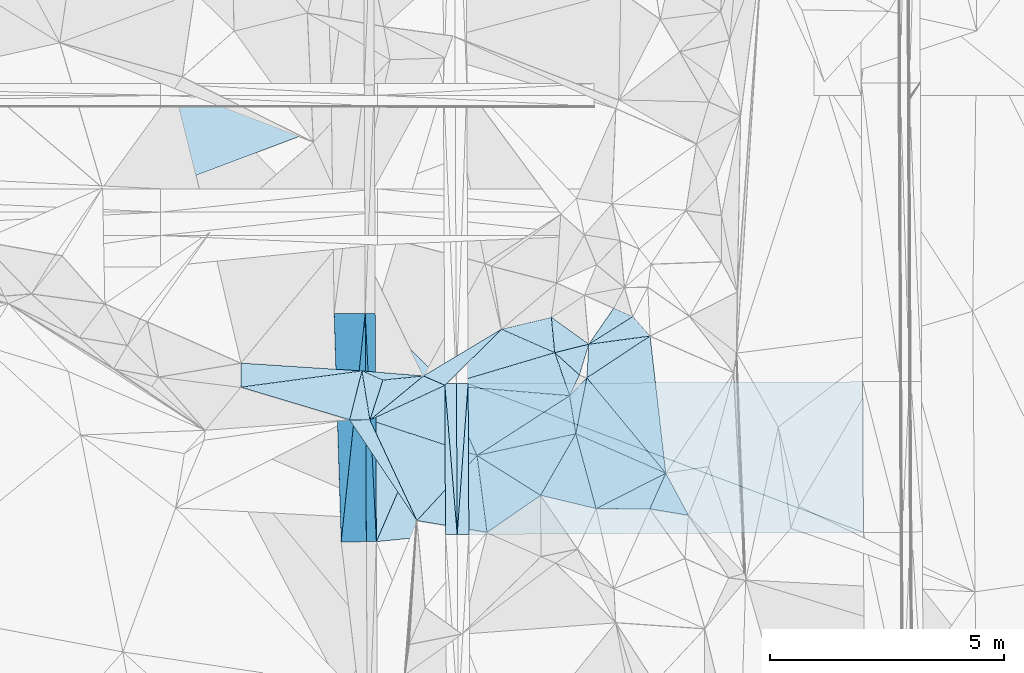
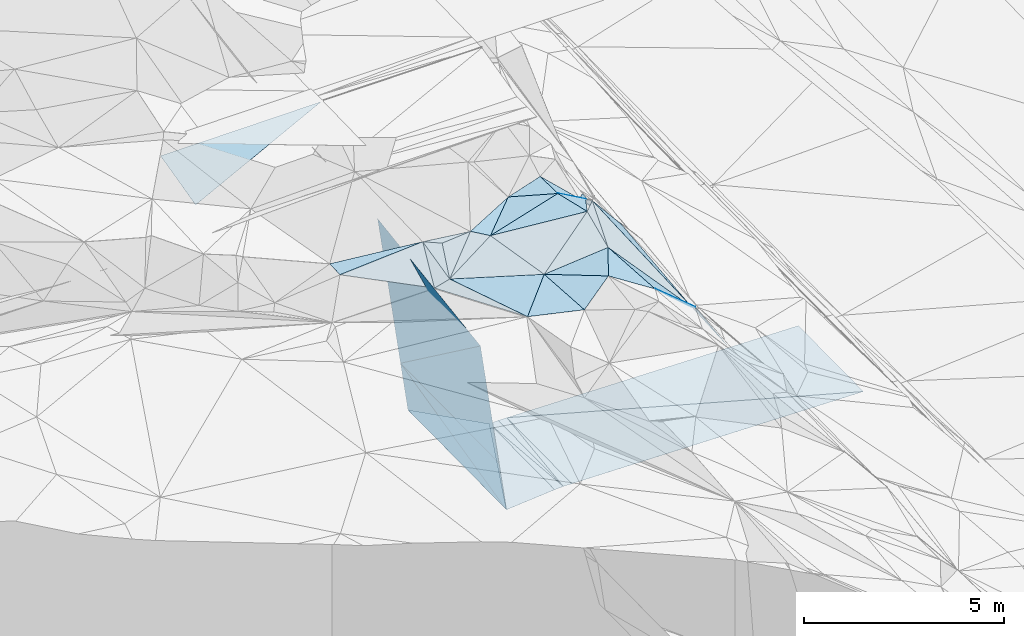
# One storey, part 58 of 275: 45 plates.
"""IFC2X3 building model written with IfcOpenShell, lengths in millimetres."""

from ifc_helpers import new_model, si_unit, frame, origin_with_axes, place, context, subcontext, project, spatial, polyline, outline, extrude, material, type_object, element, save


model = new_model("IFC2X3")

# Units and contexts
model_context = context("Model", 3, precision=1e-05, world=origin_with_axes())
body_context = subcontext(model_context, "Body", "Model", "MODEL_VIEW")
ifc_project = project(units=[si_unit("LENGTHUNIT", "METRE", prefix="MILLI"), si_unit("AREAUNIT", "SQUARE_METRE"), si_unit("VOLUMEUNIT", "CUBIC_METRE"), si_unit("MASSUNIT", "GRAM", prefix="KILO"), si_unit("TIMEUNIT", "SECOND"), si_unit("PLANEANGLEUNIT", "RADIAN"), si_unit("SOLIDANGLEUNIT", "STERADIAN"), si_unit("THERMODYNAMICTEMPERATUREUNIT", "DEGREE_CELSIUS"), si_unit("LUMINOUSINTENSITYUNIT", "LUMEN")], contexts=[model_context])

# Site, building, storey
site_placement = place(None, origin_with_axes())
site = spatial("IfcSite", under=ifc_project, at=site_placement, CompositionType="ELEMENT")
building_placement = place(site_placement, origin_with_axes())
building = spatial("IfcBuilding", under=site, at=building_placement, Name="Undefined", CompositionType="ELEMENT")
storey_placement = place(building_placement, origin_with_axes())
storey = spatial("IfcBuildingStorey", under=building, at=storey_placement, Name="Undefined", CompositionType="ELEMENT", Elevation=0.0)

# Plates
ifc_material = material()
plate_type_1 = type_object("IfcPlateType", PredefinedType="NOTDEFINED")
plate_1_placement = place(storey_placement, frame((-103762.046653991, 50894.1694006968, 42279.068715514), z_axis=(0.0498269203156431, 0.0192892523442548, -0.998571581187778), x_axis=(-0.998738273714804, -0.00530039909850709, -0.0499376249592364)))
element("IfcPlate", 1, at=plate_1_placement, inside=storey, type_object=plate_type_1, material=ifc_material, Name="00_PR", context=body_context, shape_type="SweptSolid", body=[
    extrude(outline(polyline([(0.0, 0.0), (250.312271118164, 1.46246748045087e-09), (246.36457824707, 3230.80200195313), (0.0, 0.0)])), frame((-8.85201319254618e-08, 2.18876761149539e-07, -0.5000001331573), z_axis=(0.0, 0.0, 1.0), x_axis=(1.0, 0.0, 0.0)), (0.0, 0.0, 1.0), 1.0),
])
plate_2_placement = place(storey_placement, frame((-104028.312565515, 54123.0191331993, 42328.1537156692), z_axis=(0.0498371754160968, 0.0192900898061219, -0.998571053246496), x_axis=(0.998740995725731, 0.00476009109940219, 0.0499376109710982)))
element("IfcPlate", 2, at=plate_2_placement, inside=storey, type_object=plate_type_1, material=ifc_material, Name="00_PR", context=body_context, shape_type="SweptSolid", body=[
    extrude(outline(polyline([(0.0, 0.0), (250.31233215332, -1.60071067512035e-10), (248.109878540039, 3230.66845703125), (0.0, 0.0)])), frame((-8.85201319254618e-08, 2.18876761149539e-07, -0.5000001331573), z_axis=(0.0, 0.0, 1.0), x_axis=(1.0, 0.0, 0.0)), (0.0, 0.0, 1.0), 1.0),
])
plate_3_placement = place(storey_placement, frame((-103528.352637393, 54125.4033036765, 42335.6531919543), z_axis=(-0.0200830094890469, 0.0189578951324151, -0.999618562723808), x_axis=(-0.0721347778998501, -0.997241995177913, -0.0174635870002283)))
element("IfcPlate", 3, at=plate_3_placement, inside=storey, type_object=plate_type_1, material=ifc_material, Name="00_PR", context=body_context, shape_type="SweptSolid", body=[
    extrude(outline(polyline([(0.0, 0.0), (3240.17041015625, -6.05359673500061e-09), (19.1357498168945, 249.317260742188), (0.0, 0.0)])), frame((-8.85201319254618e-08, 2.18876761149539e-07, -0.5000001331573), z_axis=(0.0, 0.0, 1.0), x_axis=(1.0, 0.0, 0.0)), (0.0, 0.0, 1.0), 1.0),
])
plate_4_placement = place(storey_placement, frame((-103762.081618957, 50894.1692334983, 42279.0681915206), z_axis=(-0.020093164801632, 0.0189586258969159, -0.999618344785826), x_axis=(0.0721347779010758, 0.997241995177758, 0.0174635870040119)))
element("IfcPlate", 4, at=plate_4_placement, inside=storey, type_object=plate_type_1, material=ifc_material, Name="00_PR", context=body_context, shape_type="SweptSolid", body=[
    extrude(outline(polyline([(0.0, 0.0), (3240.17041015625, -6.05359673500061e-09), (19.26833152771, 249.306869506836), (0.0, 0.0)])), frame((-8.85201319254618e-08, 2.18876761149539e-07, -0.5000001331573), z_axis=(0.0, 0.0, 1.0), x_axis=(1.0, 0.0, 0.0)), (0.0, 0.0, 1.0), 1.0),
])
plate_type_2 = type_object("IfcPlateType", PredefinedType="NOTDEFINED")
plate_5_placement = place(storey_placement, frame((-101746.909007034, 55542.34477326, 48219.595598845), z_axis=(-0.58668676569744, 0.0407268217810142, -0.808789196851129), x_axis=(0.69077020437291, -0.496084618041006, -0.526057579066891)))
element("IfcPlate", 5, at=plate_5_placement, inside=storey, type_object=plate_type_2, material=ifc_material, Name="00", context=body_context, shape_type="SweptSolid", body=[
    extrude(outline(polyline([(0.0, 0.0), (1159.56884765625, -2.11002770811319e-10), (471.640808105469, 601.377563476563), (0.0, 0.0)])), frame((-8.85201319254618e-08, 2.18876761149539e-07, -0.5000001331573), z_axis=(0.0, 0.0, 1.0), x_axis=(1.0, 0.0, 0.0)), (0.0, 0.0, 1.0), 1.0),
])
plate_type_3 = type_object("IfcPlateType", PredefinedType="NOTDEFINED")
plate_6_placement = place(storey_placement, frame((-106244.132911079, 50739.152833996, 47530.7782907686), z_axis=(-0.989947290912808, -0.0021282636465999, -0.141420761234847), x_axis=(0.0837842669131184, 0.79674353973498, -0.598481351846827)))
element("IfcPlate", 6, at=plate_6_placement, inside=storey, type_object=plate_type_3, material=ifc_material, Name="00_PR", context=body_context, shape_type="SweptSolid", body=[
    extrude(outline(polyline([(0.0, 0.0), (6134.95654296875, 5.02041075378656e-09), (2301.537109375, 3029.66259765625), (0.0, 0.0)])), frame((-8.85201319254618e-08, 2.18876761149539e-07, -0.5000001331573), z_axis=(0.0, 0.0, 1.0), x_axis=(1.0, 0.0, 0.0)), (0.0, 0.0, 1.0), 1.0),
])
plate_type_4 = type_object("IfcPlateType", PredefinedType="NOTDEFINED")
plate_7_placement = place(storey_placement, frame((-105491.788132013, 50743.1619801481, 42264.2932911218), z_axis=(-0.989947290912808, -0.0021282636465999, -0.141420761234847), x_axis=(-0.141419385930841, -0.000753224985709577, 0.989949488577607)))
element("IfcPlate", 7, at=plate_7_placement, inside=storey, type_object=plate_type_4, material=ifc_material, Name="00_PR", context=body_context, shape_type="SweptSolid", body=[
    extrude(outline(polyline([(0.0, 0.0), (1515.22888183594, -4.05998434871435e-09), (1608.8251953125, 4885.2021484375), (0.0, 0.0)])), frame((-8.85201319254618e-08, 2.18876761149539e-07, -0.5000001331573), z_axis=(0.0, 0.0, 1.0), x_axis=(1.0, 0.0, 0.0)), (0.0, 0.0, 1.0), 1.0),
])
plate_8_placement = place(storey_placement, frame((-105730.120088701, 55627.1397092832, 43859.1212904577), z_axis=(-0.989947290912808, -0.0021282636465999, -0.141420761234847), x_axis=(0.141420161982217, 0.000638839011322119, -0.98994945813897)))
element("IfcPlate", 8, at=plate_8_placement, inside=storey, type_object=plate_type_4, material=ifc_material, Name="00_PR", context=body_context, shape_type="SweptSolid", body=[
    extrude(outline(polyline([(0.0, 0.0), (1515.22888183594, -4.05998434871435e-09), (1609.38403320313, 4885.01806640625), (0.0, 0.0)])), frame((-8.85201319254618e-08, 2.18876761149539e-07, -0.5000001331573), z_axis=(0.0, 0.0, 1.0), x_axis=(1.0, 0.0, 0.0)), (0.0, 0.0, 1.0), 1.0),
])
plate_type_5 = type_object("IfcPlateType", PredefinedType="NOTDEFINED")
plate_9_placement = place(storey_placement, frame((-105730.120088701, 55627.1397092832, 43859.1212904577), z_axis=(-0.989947290912808, -0.0021282636465999, -0.141420761234847), x_axis=(-0.0837842669069866, -0.796743539742675, 0.598481351837441)))
element("IfcPlate", 9, at=plate_9_placement, inside=storey, type_object=plate_type_5, material=ifc_material, Name="00_PR", context=body_context, shape_type="SweptSolid", body=[
    extrude(outline(polyline([(0.0, 0.0), (6134.95654296875, 5.02041075378656e-09), (2842.0634765625, 3742.08422851563), (0.0, 0.0)])), frame((-8.85201319254618e-08, 2.18876761149539e-07, -0.5000001331573), z_axis=(0.0, 0.0, 1.0), x_axis=(1.0, 0.0, 0.0)), (0.0, 0.0, 1.0), 1.0),
])
plate_type_6 = type_object("IfcPlateType", PredefinedType="NOTDEFINED")
plate_10_placement = place(storey_placement, frame((-105491.293602614, 50743.1727441467, 42263.8640955826), z_axis=(-0.000893029804939499, 0.0194042347057233, -0.999811321286798), x_axis=(-0.00492190209821732, 0.999799524310792, 0.0194084019859799)))
element("IfcPlate", 10, at=plate_10_placement, inside=storey, type_object=plate_type_6, material=ifc_material, Name="00_PR", context=body_context, shape_type="SweptSolid", body=[
    extrude(outline(polyline([(0.0, 0.0), (4885.92529296875, 1.16124283522367e-08), (3373.21606445313, 1479.57678222656), (0.0, 0.0)])), frame((-8.85201319254618e-08, 2.18876761149539e-07, -0.5000001331573), z_axis=(0.0, 0.0, 1.0), x_axis=(1.0, 0.0, 0.0)), (0.0, 0.0, 1.0), 1.0),
])
plate_type_7 = type_object("IfcPlateType", PredefinedType="NOTDEFINED")
plate_11_placement = place(storey_placement, frame((-104012.068064245, 50892.8425331871, 42266.5680918506), z_axis=(-0.000101021010896991, 0.0190615488429448, -0.999818307069071), x_axis=(-0.994918495664482, -0.100667171080392, -0.00181869497025744)))
element("IfcPlate", 11, at=plate_11_placement, inside=storey, type_object=plate_type_7, material=ifc_material, Name="00_PR", context=body_context, shape_type="SweptSolid", body=[
    extrude(outline(polyline([(0.0, 0.0), (1486.7802734375, -4.71482053399086e-09), (-309.097930908203, 3215.984375), (0.0, 0.0)])), frame((-8.85201319254618e-08, 2.18876761149539e-07, -0.5000001331573), z_axis=(0.0, 0.0, 1.0), x_axis=(1.0, 0.0, 0.0)), (0.0, 0.0, 1.0), 1.0),
])
plate_type_8 = type_object("IfcPlateType", PredefinedType="NOTDEFINED")
plate_12_placement = place(storey_placement, frame((-103528.352637393, 54125.4033036765, 42335.6531919543), z_axis=(-0.02008628344514, 0.0189849391659867, -0.999617983682879), x_axis=(0.999788533200716, 0.00478946312094742, -0.0199987480451567)))
element("IfcPlate", 12, at=plate_12_placement, inside=storey, type_object=plate_type_8, material=ifc_material, Name="00_PR", context=body_context, shape_type="SweptSolid", body=[
    extrude(outline(polyline([(0.0, 0.0), (8443.2783203125, -4.42159944213927e-08), (8445.373046875, 3226.01611328125), (0.0, 0.0)])), frame((-8.85201319254618e-08, 2.18876761149539e-07, -0.5000001331573), z_axis=(0.0, 0.0, 1.0), x_axis=(1.0, 0.0, 0.0)), (0.0, 0.0, 1.0), 1.0),
])
plate_type_9 = type_object("IfcPlateType", PredefinedType="NOTDEFINED")
plate_13_placement = place(storey_placement, frame((-95070.5458396395, 50940.4544931018, 42105.2131907828), z_axis=(-0.0200962067385386, 0.0189586094285209, -0.999618283948057), x_axis=(-0.999785828439356, -0.00532483311878609, 0.0199985850521378)))
element("IfcPlate", 13, at=plate_13_placement, inside=storey, type_object=plate_type_9, material=ifc_material, Name="00_PR", context=body_context, shape_type="SweptSolid", body=[
    extrude(outline(polyline([(0.0, 0.0), (8443.34765625, -4.11091605201364e-09), (8443.64453125, 3230.5361328125), (0.0, 0.0)])), frame((-8.85201319254618e-08, 2.18876761149539e-07, -0.5000001331573), z_axis=(0.0, 0.0, 1.0), x_axis=(1.0, 0.0, 0.0)), (0.0, 0.0, 1.0), 1.0),
])
plate_type_10 = type_object("IfcPlateType", PredefinedType="NOTDEFINED")
plate_14_placement = place(storey_placement, frame((-104022.952609931, 54087.8671484476, 48089.5312511259), z_axis=(-0.233412279840118, 0.258147293740417, -0.937485297140354), x_axis=(-0.868234343983698, 0.378772150780406, 0.320469626829725)))
element("IfcPlate", 14, at=plate_14_placement, inside=storey, type_object=plate_type_10, material=ifc_material, Name="00", context=body_context, shape_type="SweptSolid", body=[
    extrude(outline(polyline([(0.0, 0.0), (530.471496582031, 1.74622982740402e-10), (-584.0087890625, 1600.01049804688), (0.0, 0.0)])), frame((-8.85201319254618e-08, 2.18876761149539e-07, -0.5000001331573), z_axis=(0.0, 0.0, 1.0), x_axis=(1.0, 0.0, 0.0)), (0.0, 0.0, 1.0), 1.0),
])
plate_type_11 = type_object("IfcPlateType", PredefinedType="NOTDEFINED")
plate_15_placement = place(storey_placement, frame((-100988.9224162, 54248.5335029456, 47999.6450216944), z_axis=(-0.523853065827387, 0.47069955357438, -0.709943586271562), x_axis=(0.455138312046937, -0.54983189875902, -0.700381324718268)))
element("IfcPlate", 15, at=plate_15_placement, inside=storey, type_object=plate_type_11, material=ifc_material, Name="00", context=body_context, shape_type="SweptSolid", body=[
    extrude(outline(polyline([(0.0, 0.0), (3712.26342773438, 7.31961335986853e-09), (985.382629394531, 950.484619140625), (0.0, 0.0)])), frame((-8.85201319254618e-08, 2.18876761149539e-07, -0.5000001331573), z_axis=(0.0, 0.0, 1.0), x_axis=(1.0, 0.0, 0.0)), (0.0, 0.0, 1.0), 1.0),
])
plate_type_12 = type_object("IfcPlateType", PredefinedType="NOTDEFINED")
plate_16_placement = place(storey_placement, frame((-101674.962376392, 54786.8267694161, 48129.5048584038), z_axis=(0.0632313953986985, 0.12395206460985, -0.990271516461465), x_axis=(-0.915263981962501, 0.402774644778047, -0.00802675812924839)))
element("IfcPlate", 16, at=plate_16_placement, inside=storey, type_object=plate_type_12, material=ifc_material, Name="00", context=body_context, shape_type="SweptSolid", body=[
    extrude(outline(polyline([(0.0, 0.0), (1245.8330078125, -6.76664058119059e-10), (369.150573730469, 669.199401855469), (0.0, 0.0)])), frame((-8.85201319254618e-08, 2.18876761149539e-07, -0.5000001331573), z_axis=(0.0, 0.0, 1.0), x_axis=(1.0, 0.0, 0.0)), (0.0, 0.0, 1.0), 1.0),
])
plate_type_13 = type_object("IfcPlateType", PredefinedType="NOTDEFINED")
plate_17_placement = place(storey_placement, frame((-110108.256790268, 58293.3213399006, 48604.6889341053), z_axis=(0.00684061845241066, 0.242529579853101, -0.970119894052002), x_axis=(5.55829351537207e-05, 0.970142499049491, 0.242535623050607)))
element("IfcPlate", 17, at=plate_17_placement, inside=storey, type_object=plate_type_13, material=ifc_material, Name="00_PR", context=body_context, shape_type="SweptSolid", body=[
    extrude(outline(polyline([(0.0, 0.0), (1803.85876464844, 6.72298483550549e-09), (1811.77587890625, 4638.87841796875), (0.0, 0.0)])), frame((-8.85201319254618e-08, 2.18876761149539e-07, -0.5000001331573), z_axis=(0.0, 0.0, 1.0), x_axis=(1.0, 0.0, 0.0)), (0.0, 0.0, 1.0), 1.0),
])
plate_type_14 = type_object("IfcPlateType", PredefinedType="NOTDEFINED")
plate_18_placement = place(storey_placement, frame((-101147.16709207, 54309.3304796496, 48059.6047511342), z_axis=(-0.465025991329188, -0.398603220742438, -0.790484851089546), x_axis=(-0.738346073997483, 0.66728210474532, 0.0978757768764019)))
element("IfcPlate", 18, at=plate_18_placement, inside=storey, type_object=plate_type_14, material=ifc_material, Name="00", context=body_context, shape_type="SweptSolid", body=[
    extrude(outline(polyline([(0.0, 0.0), (715.192260742188, 1.16415321826935e-09), (246.087661743164, 784.117858886719), (0.0, 0.0)])), frame((-8.85201319254618e-08, 2.18876761149539e-07, -0.5000001331573), z_axis=(0.0, 0.0, 1.0), x_axis=(1.0, 0.0, 0.0)), (0.0, 0.0, 1.0), 1.0),
])
plate_type_15 = type_object("IfcPlateType", PredefinedType="NOTDEFINED")
plate_19_placement = place(storey_placement, frame((-105799.064566728, 54396.0678337138, 48339.5610082653), z_axis=(0.0513489365078653, 0.475981180494157, -0.877955125581541), x_axis=(0.904036803614412, -0.395707394657458, -0.161657401698913)))
element("IfcPlate", 19, at=plate_19_placement, inside=storey, type_object=plate_type_15, material=ifc_material, Name="00", context=body_context, shape_type="SweptSolid", body=[
    extrude(outline(polyline([(0.0, 0.0), (494.873718261719, -1.88083504326642e-09), (659.764282226563, 1006.03735351563), (0.0, 0.0)])), frame((-8.85201319254618e-08, 2.18876761149539e-07, -0.5000001331573), z_axis=(0.0, 0.0, 1.0), x_axis=(1.0, 0.0, 0.0)), (0.0, 0.0, 1.0), 1.0),
])
plate_type_16 = type_object("IfcPlateType", PredefinedType="NOTDEFINED")
plate_20_placement = place(storey_placement, frame((-100988.988290364, 54248.1334484045, 47999.6602603322), z_axis=(-0.655601111008881, -0.329411130320671, -0.67946706356142), x_axis=(0.0525587638989863, 0.877739007721382, -0.476247635859427)))
element("IfcPlate", 20, at=plate_20_placement, inside=storey, type_object=plate_type_16, material=ifc_material, Name="00", context=body_context, shape_type="SweptSolid", body=[
    extrude(outline(polyline([(0.0, 0.0), (818.901733398438, 7.27595761418343e-11), (1684.45129394531, 1680.21545410156), (0.0, 0.0)])), frame((-8.85201319254618e-08, 2.18876761149539e-07, -0.5000001331573), z_axis=(0.0, 0.0, 1.0), x_axis=(1.0, 0.0, 0.0)), (0.0, 0.0, 1.0), 1.0),
])
plate_type_17 = type_object("IfcPlateType", PredefinedType="NOTDEFINED")
plate_21_placement = place(storey_placement, frame((-108389.948837513, 54048.6101273581, 48449.5009397336), z_axis=(-0.0475993406432171, 0.0389654953539523, -0.998106203237988), x_axis=(0.00393270977083742, 0.999238397367914, 0.0388221459924721)))
element("IfcPlate", 21, at=plate_21_placement, inside=storey, type_object=plate_type_17, material=ifc_material, Name="00", context=body_context, shape_type="SweptSolid", body=[
    extrude(outline(polyline([(0.0, 0.0), (515.169860839844, -2.03726813197136e-10), (352.893310546875, 2592.40551757813), (0.0, 0.0)])), frame((-8.85201319254618e-08, 2.18876761149539e-07, -0.5000001331573), z_axis=(0.0, 0.0, 1.0), x_axis=(1.0, 0.0, 0.0)), (0.0, 0.0, 1.0), 1.0),
])
plate_type_18 = type_object("IfcPlateType", PredefinedType="NOTDEFINED")
plate_22_placement = place(storey_placement, frame((-100790.293710717, 51449.6726089859, 46929.5573040336), z_axis=(-0.447027369949756, 0.127542400060147, -0.885380972634211), x_axis=(-0.861123508756882, 0.206570957758807, 0.464537126693707)))
element("IfcPlate", 22, at=plate_22_placement, inside=storey, type_object=plate_type_18, material=ifc_material, Name="00", context=body_context, shape_type="SweptSolid", body=[
    extrude(outline(polyline([(0.0, 0.0), (1377.71545410156, 4.34374669566751e-09), (913.904235839844, 1455.80871582031), (0.0, 0.0)])), frame((-8.85201319254618e-08, 2.18876761149539e-07, -0.5000001331573), z_axis=(0.0, 0.0, 1.0), x_axis=(1.0, 0.0, 0.0)), (0.0, 0.0, 1.0), 1.0),
])
plate_type_19 = type_object("IfcPlateType", PredefinedType="NOTDEFINED")
plate_23_placement = place(storey_placement, frame((-100004.58393952, 55558.0614423126, 46459.6555210029), z_axis=(-0.673621013158224, -0.267560383254327, -0.688945695932913), x_axis=(0.625229940446472, -0.703375052186391, -0.338158332044463)))
element("IfcPlate", 23, at=plate_23_placement, inside=storey, type_object=plate_type_19, material=ifc_material, Name="00", context=body_context, shape_type="SweptSolid", body=[
    extrude(outline(polyline([(0.0, 0.0), (591.438903808594, 3.92901711165905e-10), (-561.680969238281, 1497.5361328125), (0.0, 0.0)])), frame((-8.85201319254618e-08, 2.18876761149539e-07, -0.5000001331573), z_axis=(0.0, 0.0, 1.0), x_axis=(1.0, 0.0, 0.0)), (0.0, 0.0, 1.0), 1.0),
])
plate_type_20 = type_object("IfcPlateType", PredefinedType="NOTDEFINED")
plate_24_placement = place(storey_placement, frame((-100412.465496825, 55738.8097774379, 47109.7202382953), z_axis=(-0.805668079926262, 0.194541702806155, -0.559510921124166), x_axis=(0.5173424800074, -0.228998778856811, -0.824570383691945)))
element("IfcPlate", 24, at=plate_24_placement, inside=storey, type_object=plate_type_20, material=ifc_material, Name="00", context=body_context, shape_type="SweptSolid", body=[
    extrude(outline(polyline([(0.0, 0.0), (788.289306640625, -2.69938027486205e-09), (-511.614196777344, 931.853454589844), (0.0, 0.0)])), frame((-8.85201319254618e-08, 2.18876761149539e-07, -0.5000001331573), z_axis=(0.0, 0.0, 1.0), x_axis=(1.0, 0.0, 0.0)), (0.0, 0.0, 1.0), 1.0),
])
plate_type_21 = type_object("IfcPlateType", PredefinedType="NOTDEFINED")
plate_25_placement = place(storey_placement, frame((-101675.018825149, 54786.8102593332, 48129.5026845981), z_axis=(-0.0496641829847228, 0.0909354786842906, -0.994617618808816), x_axis=(0.738346073993914, -0.667282104749, -0.0978757768782386)))
element("IfcPlate", 25, at=plate_25_placement, inside=storey, type_object=plate_type_21, material=ifc_material, Name="00", context=body_context, shape_type="SweptSolid", body=[
    extrude(outline(polyline([(0.0, 0.0), (715.192260742188, 1.16415321826935e-09), (858.929870605469, 468.550445556641), (0.0, 0.0)])), frame((-8.85201319254618e-08, 2.18876761149539e-07, -0.5000001331573), z_axis=(0.0, 0.0, 1.0), x_axis=(1.0, 0.0, 0.0)), (0.0, 0.0, 1.0), 1.0),
])
plate_type_22 = type_object("IfcPlateType", PredefinedType="NOTDEFINED")
plate_26_placement = place(storey_placement, frame((-99299.4702075549, 52207.2171404325, 45399.7067906414), z_axis=(-0.806085523060392, 0.0797108898749618, -0.586406261518239), x_axis=(-0.455138312048106, 0.549831898760767, 0.700381324716137)))
element("IfcPlate", 26, at=plate_26_placement, inside=storey, type_object=plate_type_22, material=ifc_material, Name="00", context=body_context, shape_type="SweptSolid", body=[
    extrude(outline(polyline([(0.0, 0.0), (3712.26342773438, 7.31961335986853e-09), (2368.74340820313, 1963.53100585938), (0.0, 0.0)])), frame((-8.85201319254618e-08, 2.18876761149539e-07, -0.5000001331573), z_axis=(0.0, 0.0, 1.0), x_axis=(1.0, 0.0, 0.0)), (0.0, 0.0, 1.0), 1.0),
])
plate_type_23 = type_object("IfcPlateType", PredefinedType="NOTDEFINED")
plate_27_placement = place(storey_placement, frame((-101355.956192253, 53867.3000402465, 48029.5027197516), z_axis=(-0.0138298939410231, 0.103361304849351, -0.99454772368822), x_axis=(-0.996349277645582, 0.0823749927897687, 0.0224160098593203)))
element("IfcPlate", 27, at=plate_27_placement, inside=storey, type_object=plate_type_23, material=ifc_material, Name="00", context=body_context, shape_type="SweptSolid", body=[
    extrude(outline(polyline([(0.0, 0.0), (2676.65844726563, 1.61526259034872e-08), (395.866729736328, 894.756713867188), (0.0, 0.0)])), frame((-8.85201319254618e-08, 2.18876761149539e-07, -0.5000001331573), z_axis=(0.0, 0.0, 1.0), x_axis=(1.0, 0.0, 0.0)), (0.0, 0.0, 1.0), 1.0),
])
plate_type_24 = type_object("IfcPlateType", PredefinedType="NOTDEFINED")
plate_28_placement = place(storey_placement, frame((-101356.050995065, 53867.5431122881, 48029.6091310154), z_axis=(-0.203438938296475, 0.589505282117023, -0.781726372038793), x_axis=(0.124917821229491, -0.77627020394737, -0.61789975594977)))
element("IfcPlate", 28, at=plate_28_placement, inside=storey, type_object=plate_type_24, material=ifc_material, Name="00", context=body_context, shape_type="SweptSolid", body=[
    extrude(outline(polyline([(0.0, 0.0), (1051.95056152344, -4.43833414465189e-09), (1024.57287597656, 2172.22241210938), (0.0, 0.0)])), frame((-8.85201319254618e-08, 2.18876761149539e-07, -0.5000001331573), z_axis=(0.0, 0.0, 1.0), x_axis=(1.0, 0.0, 0.0)), (0.0, 0.0, 1.0), 1.0),
])
plate_type_25 = type_object("IfcPlateType", PredefinedType="NOTDEFINED")
plate_29_placement = place(storey_placement, frame((-100988.931740391, 54248.5321498538, 47999.6511859805), z_axis=(-0.54250726732788, 0.467992207673405, -0.697616770478899), x_axis=(-0.172290998689963, -0.874778173636847, -0.452856443808628)))
element("IfcPlate", 29, at=plate_29_placement, inside=storey, type_object=plate_type_25, material=ifc_material, Name="00", context=body_context, shape_type="SweptSolid", body=[
    extrude(outline(polyline([(0.0, 0.0), (1369.08728027344, 5.60248736292124e-09), (383.028900146484, 366.454437255859), (0.0, 0.0)])), frame((-8.85201319254618e-08, 2.18876761149539e-07, -0.5000001331573), z_axis=(0.0, 0.0, 1.0), x_axis=(1.0, 0.0, 0.0)), (0.0, 0.0, 1.0), 1.0),
])
plate_type_26 = type_object("IfcPlateType", PredefinedType="NOTDEFINED")
plate_30_placement = place(storey_placement, frame((-101224.900186928, 53050.6512745163, 47379.6512369883), z_axis=(-0.716568497302194, 0.00159456814766526, -0.697514907386572), x_axis=(0.666765356341244, -0.292083137964427, -0.685646702099549)))
element("IfcPlate", 30, at=plate_30_placement, inside=storey, type_object=plate_type_26, material=ifc_material, Name="00", context=body_context, shape_type="SweptSolid", body=[
    extrude(outline(polyline([(0.0, 0.0), (2887.78466796875, -1.18961906991899e-09), (1065.86901855469, 1348.5263671875), (0.0, 0.0)])), frame((-8.85201319254618e-08, 2.18876761149539e-07, -0.5000001331573), z_axis=(0.0, 0.0, 1.0), x_axis=(1.0, 0.0, 0.0)), (0.0, 0.0, 1.0), 1.0),
])
plate_type_27 = type_object("IfcPlateType", PredefinedType="NOTDEFINED")
plate_31_placement = place(storey_placement, frame((-99639.9964477967, 51444.1601210725, 45979.6311525087), z_axis=(-0.610519361876732, -0.28825115842594, -0.737683792989741), x_axis=(-0.771059909896915, 0.00355548585656911, 0.6367526787302)))
element("IfcPlate", 31, at=plate_31_placement, inside=storey, type_object=plate_type_27, material=ifc_material, Name="00", context=body_context, shape_type="SweptSolid", body=[
    extrude(outline(polyline([(0.0, 0.0), (1491.94506835938, 6.69388100504875e-10), (-629.245727539063, 799.030578613281), (0.0, 0.0)])), frame((-8.85201319254618e-08, 2.18876761149539e-07, -0.5000001331573), z_axis=(0.0, 0.0, 1.0), x_axis=(1.0, 0.0, 0.0)), (0.0, 0.0, 1.0), 1.0),
])
plate_type_28 = type_object("IfcPlateType", PredefinedType="NOTDEFINED")
plate_32_placement = place(storey_placement, frame((-104022.821977066, 54087.9045558719, 48089.5287295175), z_axis=(0.0278522642834534, 0.332962204227896, -0.942528737986267), x_axis=(0.396876061990831, -0.869077264454459, -0.295286470782196)))
element("IfcPlate", 32, at=plate_32_placement, inside=storey, type_object=plate_type_28, material=ifc_material, Name="00", context=body_context, shape_type="SweptSolid", body=[
    extrude(outline(polyline([(0.0, 0.0), (1727.13635253906, -1.55705492943525e-09), (99.7026062011719, 1794.42456054688), (0.0, 0.0)])), frame((-8.85201319254618e-08, 2.18876761149539e-07, -0.5000001331573), z_axis=(0.0, 0.0, 1.0), x_axis=(1.0, 0.0, 0.0)), (0.0, 0.0, 1.0), 1.0),
])
plate_type_29 = type_object("IfcPlateType", PredefinedType="NOTDEFINED")
plate_33_placement = place(storey_placement, frame((-102815.253264223, 55288.5603612405, 48119.5000723707), z_axis=(0.0136986781581393, 0.0112033009234968, -0.999843403871395), x_axis=(0.915263981963234, -0.402774644776404, 0.00802675812811487)))
element("IfcPlate", 33, at=plate_33_placement, inside=storey, type_object=plate_type_29, material=ifc_material, Name="00", context=body_context, shape_type="SweptSolid", body=[
    extrude(outline(polyline([(0.0, 0.0), (1245.8330078125, -6.76664058119059e-10), (-621.832885742188, 1585.69348144531), (0.0, 0.0)])), frame((-8.85201319254618e-08, 2.18876761149539e-07, -0.5000001331573), z_axis=(0.0, 0.0, 1.0), x_axis=(1.0, 0.0, 0.0)), (0.0, 0.0, 1.0), 1.0),
])
plate_type_30 = type_object("IfcPlateType", PredefinedType="NOTDEFINED")
plate_34_placement = place(storey_placement, frame((-105629.433801283, 53344.8548642058, 47779.5818122696), z_axis=(0.252934500595751, 0.486334171992927, -0.83636308596227), x_axis=(-0.959155207415955, 0.0128669528039033, -0.282587560965444)))
element("IfcPlate", 34, at=plate_34_placement, inside=storey, type_object=plate_type_30, material=ifc_material, Name="00", context=body_context, shape_type="SweptSolid", body=[
    extrude(outline(polyline([(0.0, 0.0), (452.956939697266, -9.74978320300579e-10), (17.8824939727783, 1202.94653320313), (0.0, 0.0)])), frame((-8.85201319254618e-08, 2.18876761149539e-07, -0.5000001331573), z_axis=(0.0, 0.0, 1.0), x_axis=(1.0, 0.0, 0.0)), (0.0, 0.0, 1.0), 1.0),
])
plate_type_31 = type_object("IfcPlateType", PredefinedType="NOTDEFINED")
plate_35_placement = place(storey_placement, frame((-103337.347864757, 52586.775195616, 47579.5035554329), z_axis=(0.0579279688216475, 0.104120104236963, -0.992876303635998), x_axis=(0.84743816505322, -0.530857590784256, -0.00622693487730684)))
element("IfcPlate", 35, at=plate_35_placement, inside=storey, type_object=plate_type_31, material=ifc_material, Name="00", context=body_context, shape_type="SweptSolid", body=[
    extrude(outline(polyline([(0.0, 0.0), (1605.92651367188, -4.46925696451217e-09), (1054.40686035156, 1289.50610351563), (0.0, 0.0)])), frame((-8.85201319254618e-08, 2.18876761149539e-07, -0.5000001331573), z_axis=(0.0, 0.0, 1.0), x_axis=(1.0, 0.0, 0.0)), (0.0, 0.0, 1.0), 1.0),
])
plate_type_32 = type_object("IfcPlateType", PredefinedType="NOTDEFINED")
plate_36_placement = place(storey_placement, frame((-103337.374079586, 52586.8851122216, 47579.5269651219), z_axis=(0.00549888098818489, 0.323953079799773, -0.946057167615213), x_axis=(-0.396876062009067, 0.869077264450654, 0.295286470768885)))
element("IfcPlate", 36, at=plate_36_placement, inside=storey, type_object=plate_type_32, material=ifc_material, Name="00", context=body_context, shape_type="SweptSolid", body=[
    extrude(outline(polyline([(0.0, 0.0), (1727.13635253906, -1.55705492943525e-09), (459.373107910156, 2357.3876953125), (0.0, 0.0)])), frame((-8.85201319254618e-08, 2.18876761149539e-07, -0.5000001331573), z_axis=(0.0, 0.0, 1.0), x_axis=(1.0, 0.0, 0.0)), (0.0, 0.0, 1.0), 1.0),
])
plate_type_33 = type_object("IfcPlateType", PredefinedType="NOTDEFINED")
plate_37_placement = place(storey_placement, frame((-98813.8956881058, 51306.6193654601, 44619.7408595878), z_axis=(-0.855130128141547, -0.01221492286623, -0.518269485503433), x_axis=(-0.517279255097373, 0.0861975149023047, 0.85146471487113)))
element("IfcPlate", 37, at=plate_37_placement, inside=storey, type_object=plate_type_33, material=ifc_material, Name="00", context=body_context, shape_type="SweptSolid", body=[
    extrude(outline(polyline([(0.0, 0.0), (1597.24768066406, 2.43016984313726e-09), (992.958129882813, 818.067321777344), (0.0, 0.0)])), frame((-8.85201319254618e-08, 2.18876761149539e-07, -0.5000001331573), z_axis=(0.0, 0.0, 1.0), x_axis=(1.0, 0.0, 0.0)), (0.0, 0.0, 1.0), 1.0),
])
plate_type_34 = type_object("IfcPlateType", PredefinedType="NOTDEFINED")
plate_38_placement = place(storey_placement, frame((-101224.577622654, 53050.5992810465, 47379.5039061916), z_axis=(-0.07143488018104, -0.102397392220894, -0.992175303038672), x_axis=(-0.492118608716359, -0.861600590913489, 0.124353112918823)))
element("IfcPlate", 38, at=plate_38_placement, inside=storey, type_object=plate_type_34, material=ifc_material, Name="00", context=body_context, shape_type="SweptSolid", body=[
    extrude(outline(polyline([(0.0, 0.0), (1527.90710449219, -6.11180439591408e-09), (1464.35607910156, 1604.66857910156), (0.0, 0.0)])), frame((-8.85201319254618e-08, 2.18876761149539e-07, -0.5000001331573), z_axis=(0.0, 0.0, 1.0), x_axis=(1.0, 0.0, 0.0)), (0.0, 0.0, 1.0), 1.0),
])
plate_type_35 = type_object("IfcPlateType", PredefinedType="NOTDEFINED")
plate_39_placement = place(storey_placement, frame((-105629.5858659, 53344.8623557954, 47779.5681188029), z_axis=(-0.0511891030304544, 0.50131629862965, -0.863748600264686), x_axis=(0.272550086768211, 0.839064226141137, 0.47083720606258)))
element("IfcPlate", 39, at=plate_39_placement, inside=storey, type_object=plate_type_35, material=ifc_material, Name="00", context=body_context, shape_type="SweptSolid", body=[
    extrude(outline(polyline([(0.0, 0.0), (1019.46063232422, -2.11002770811319e-09), (1330.50744628906, 815.505920410156), (0.0, 0.0)])), frame((-8.85201319254618e-08, 2.18876761149539e-07, -0.5000001331573), z_axis=(0.0, 0.0, 1.0), x_axis=(1.0, 0.0, 0.0)), (0.0, 0.0, 1.0), 1.0),
])
plate_type_36 = type_object("IfcPlateType", PredefinedType="NOTDEFINED")
plate_40_placement = place(storey_placement, frame((-105799.145501716, 54396.1127314148, 48339.5914341507), z_axis=(-0.110521441473118, 0.565776613610015, -0.817118005227328), x_axis=(-0.207101815792932, -0.817217342275863, -0.537833295156451)))
element("IfcPlate", 40, at=plate_40_placement, inside=storey, type_object=plate_type_36, material=ifc_material, Name="00", context=body_context, shape_type="SweptSolid", body=[
    extrude(outline(polyline([(0.0, 0.0), (1279.20678710938, 5.82076609134674e-11), (761.1748046875, 2503.140625), (0.0, 0.0)])), frame((-8.85201319254618e-08, 2.18876761149539e-07, -0.5000001331573), z_axis=(0.0, 0.0, 1.0), x_axis=(1.0, 0.0, 0.0)), (0.0, 0.0, 1.0), 1.0),
])
plate_type_37 = type_object("IfcPlateType", PredefinedType="NOTDEFINED")
plate_41_placement = place(storey_placement, frame((-104623.036896965, 51193.9865521395, 47579.5020478767), z_axis=(-0.0665751049598346, 0.0614537242972586, -0.995887139775177), x_axis=(-0.422398426414285, 0.902516164415579, 0.0839293889607647)))
element("IfcPlate", 41, at=plate_41_placement, inside=storey, type_object=plate_type_37, material=ifc_material, Name="00", context=body_context, shape_type="SweptSolid", body=[
    extrude(outline(polyline([(0.0, 0.0), (2382.95556640625, 4.94765117764473e-09), (713.948303222656, 1755.82312011719), (0.0, 0.0)])), frame((-8.85201319254618e-08, 2.18876761149539e-07, -0.5000001331573), z_axis=(0.0, 0.0, 1.0), x_axis=(1.0, 0.0, 0.0)), (0.0, 0.0, 1.0), 1.0),
])
plate_type_38 = type_object("IfcPlateType", PredefinedType="NOTDEFINED")
plate_42_placement = place(storey_placement, frame((-104622.864341893, 51194.0645049263, 47579.5322379289), z_axis=(0.278536061223658, 0.217358659424075, -0.935506748116431), x_axis=(-0.555381893253725, 0.831132308035911, 0.0277495799032558)))
element("IfcPlate", 42, at=plate_42_placement, inside=storey, type_object=plate_type_38, material=ifc_material, Name="00", context=body_context, shape_type="SweptSolid", body=[
    extrude(outline(polyline([(0.0, 0.0), (2594.6337890625, -6.86122803017497e-09), (2352.052734375, 382.523773193359), (0.0, 0.0)])), frame((-8.85201319254618e-08, 2.18876761149539e-07, -0.5000001331573), z_axis=(0.0, 0.0, 1.0), x_axis=(1.0, 0.0, 0.0)), (0.0, 0.0, 1.0), 1.0),
])
plate_type_39 = type_object("IfcPlateType", PredefinedType="NOTDEFINED")
plate_43_placement = place(storey_placement, frame((-104483.42551385, 54288.8230477647, 48259.5255929755), z_axis=(-0.0320917420357644, 0.314287851327641, -0.948785153025154), x_axis=(-0.994827250399885, -0.101581208211976, -1.83630469271115e-10)))
element("IfcPlate", 43, at=plate_43_placement, inside=storey, type_object=plate_type_39, material=ifc_material, Name="00", context=body_context, shape_type="SweptSolid", body=[
    extrude(outline(polyline([(0.0, 0.0), (872.8115234375, -4.30736690759659e-09), (1297.9892578125, 253.227035522461), (0.0, 0.0)])), frame((-8.85201319254618e-08, 2.18876761149539e-07, -0.5000001331573), z_axis=(0.0, 0.0, 1.0), x_axis=(1.0, 0.0, 0.0)), (0.0, 0.0, 1.0), 1.0),
])
plate_type_40 = type_object("IfcPlateType", PredefinedType="NOTDEFINED")
plate_44_placement = place(storey_placement, frame((-105629.601064339, 53344.8759429181, 47779.5774550035), z_axis=(-0.0813718909160763, 0.528454637460253, -0.845052845398141), x_axis=(0.734455567433748, 0.604951694261887, 0.307584894094695)))
element("IfcPlate", 44, at=plate_44_placement, inside=storey, type_object=plate_type_40, material=ifc_material, Name="00", context=body_context, shape_type="SweptSolid", body=[
    extrude(outline(polyline([(0.0, 0.0), (1560.54479980469, 1.10594555735588e-09), (1724.97448730469, 504.343994140625), (0.0, 0.0)])), frame((-8.85201319254618e-08, 2.18876761149539e-07, -0.5000001331573), z_axis=(0.0, 0.0, 1.0), x_axis=(1.0, 0.0, 0.0)), (0.0, 0.0, 1.0), 1.0),
])
plate_type_41 = type_object("IfcPlateType", PredefinedType="NOTDEFINED")
plate_45_placement = place(storey_placement, frame((-103124.381851152, 50942.4986128819, 47419.5038908021), z_axis=(-0.0917187578249907, 0.0846631665640288, -0.992179327385122), x_axis=(-0.98078815669451, 0.164591381378926, 0.104710404753116)))
element("IfcPlate", 45, at=plate_45_placement, inside=storey, type_object=plate_type_41, material=ifc_material, Name="00", context=body_context, shape_type="SweptSolid", body=[
    extrude(outline(polyline([(0.0, 0.0), (1528.02392578125, 8.41100700199604e-09), (496.333862304688, 1590.04797363281), (0.0, 0.0)])), frame((-8.85201319254618e-08, 2.18876761149539e-07, -0.5000001331573), z_axis=(0.0, 0.0, 1.0), x_axis=(1.0, 0.0, 0.0)), (0.0, 0.0, 1.0), 1.0),
])

save(model, "model.ifc")
